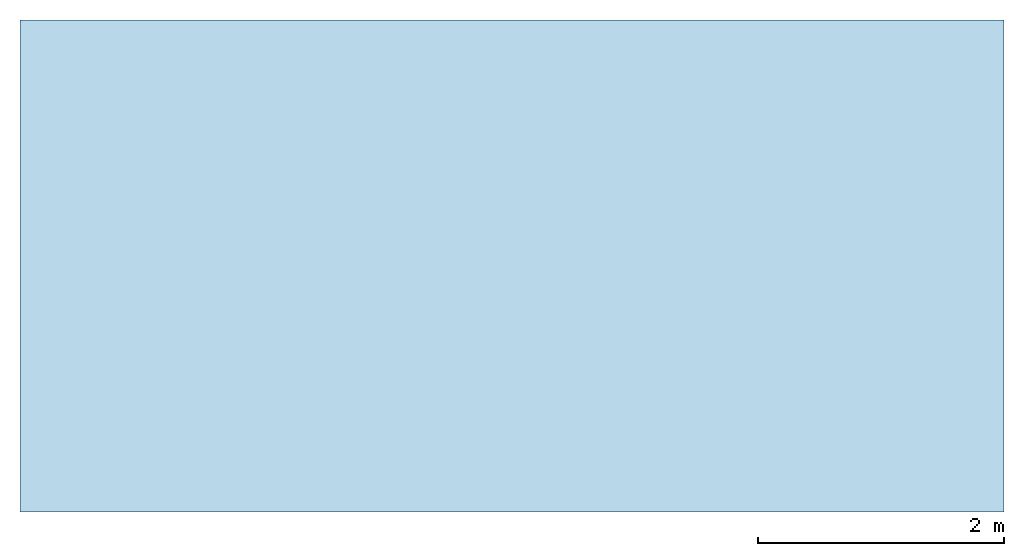
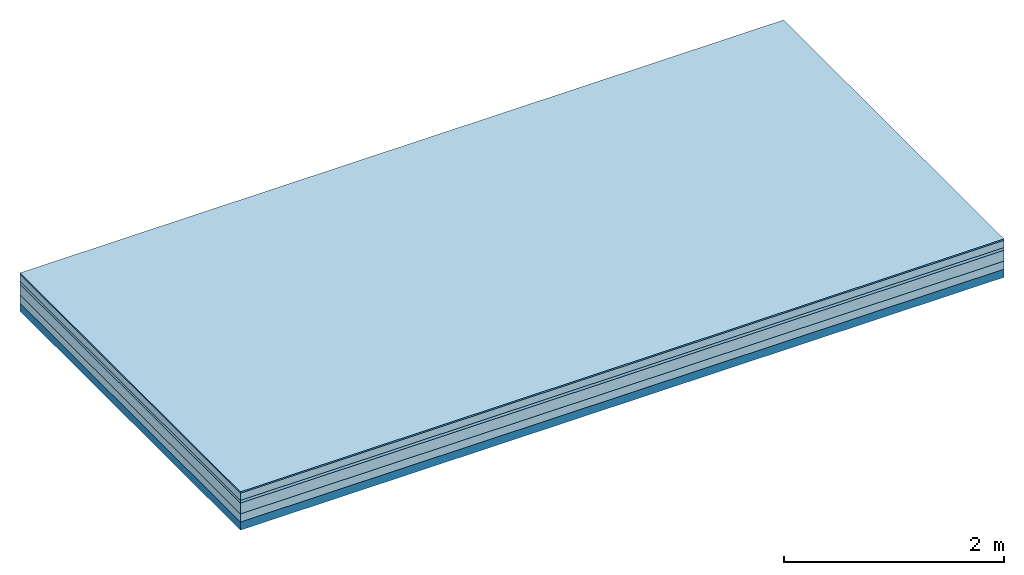
# One storey: 5 plates, 1 member, 1 element without a shape of its own.
"""IFC4 building model written with IfcOpenShell, lengths in metres."""

from ifc_helpers import new_model, si_unit, derived_unit, direction, frame, frame_2d, origin, origin_with_axes, place, context, project, spatial, rectangle, extrude, material, layer, layer_set, type_object, element, aggregate, save


model = new_model("IFC4")

# Units and contexts
plan_context = context("Plan", 3, precision=1e-05, world=origin(), true_north=direction((0.0, 1.0)))
model_context = context("Model", 3, precision=1e-05, world=origin(), true_north=direction((0.0, 1.0)))
ifc_project = project(units=[si_unit("LENGTHUNIT", "METRE"), derived_unit("SOUNDPRESSUREUNIT", [(si_unit("PRESSUREUNIT", "PASCAL", prefix="MICRO"), 0)]), si_unit("ENERGYUNIT", "JOULE", prefix="MEGA"), si_unit("MASSUNIT", "GRAM", prefix="KILO"), derived_unit("THERMALTRANSMITTANCEUNIT", [(si_unit("POWERUNIT", "WATT"), 1), (si_unit("AREAUNIT", "SQUARE_METRE"), -1), (si_unit("THERMODYNAMICTEMPERATUREUNIT", "KELVIN"), -1)]), derived_unit("AREADENSITYUNIT", [(si_unit("MASSUNIT", "GRAM", prefix="KILO"), 1), (si_unit("AREAUNIT", "SQUARE_METRE"), -1)]), derived_unit("USERDEFINED", [(si_unit("ENERGYUNIT", "JOULE", prefix="MEGA"), 1), (si_unit("AREAUNIT", "SQUARE_METRE"), -1)])], contexts=[plan_context, model_context])

# Site, building, storey
site = spatial("IfcSite", under=ifc_project)
building_placement = place(None, origin())
building = spatial("IfcBuilding", under=site, at=building_placement)
storey_placement = place(building_placement, origin())
storey = spatial("IfcBuildingStorey", under=building, at=storey_placement)

# Slab, member, plates
ifc_material_1 = material(Category="11.013")
ifc_layer_1 = layer(ifc_material_1, 0.015, Name="Flooring")
ifc_material_2 = material(Name="Cement screed", Category="04.006")
ifc_layer_2 = layer(ifc_material_2, 0.08, Name="On-material")
ifc_material_3 = material(Name="Wood fiber generic product", Category="10.009")
ifc_layer_3 = layer(ifc_material_3, 0.03, Name="Impact sound insulation")
ifc_material_4 = material(Name="Cement screed with EPS", Category="04.006")
ifc_layer_4 = layer(ifc_material_4, 0.12, Name="on Supporting structure")
ifc_material_5 = material(Category="01.002")
ifc_layer_5 = layer(ifc_material_5, 0.09, Name="Sub-floor")
ifc_material_6 = material(Name="Rigid, of the art")
ifc_layer_6 = layer(ifc_material_6, 0.0, Name="Bond")
ifc_layer_7 = layer(None, 0.09, Name="Supporting structure")
ifc_layer_set = layer_set([ifc_layer_1, ifc_layer_2, ifc_layer_3, ifc_layer_4, ifc_layer_5, ifc_layer_6, ifc_layer_7])
slab_type = type_object("IfcSlabType", Name="A2216", PredefinedType="NOTDEFINED", material=ifc_layer_set)
slab_placement = place(None, frame((0.0, 0.0, 0.0), z_axis=(0.0, 0.0, -1.0), x_axis=(1.0, 0.0, 0.0)))
slab = element("IfcSlab", 1, at=slab_placement, inside=storey, type_object=slab_type, material=ifc_layer_set, Name="Slab #1")
ifc_material_7 = material(Name="Solid timber panel")
member_placement = place(slab_placement, origin())
member = element("IfcMember", 2, at=member_placement, material=ifc_material_7, Name="Supporting structure", context=plan_context, shape_type="SweptSolid", body=[
    extrude(rectangle(XDim=1.0, YDim=0.09, at=frame_2d((0.5, 0.045), x_axis=(1.0, 0.0))), frame((0.0, 4.0, 0.335), z_axis=(0.0, -1.0, 0.0), x_axis=(1.0, 0.0, 0.0)), (0.0, 0.0, 1.0), 4.0),
    extrude(rectangle(XDim=1.0, YDim=0.09, at=frame_2d((0.5, 0.045), x_axis=(1.0, 0.0))), frame((1.0, 4.0, 0.335), z_axis=(0.0, -1.0, 0.0), x_axis=(1.0, 0.0, 0.0)), (0.0, 0.0, 1.0), 4.0),
    extrude(rectangle(XDim=1.0, YDim=0.09, at=frame_2d((0.5, 0.045), x_axis=(1.0, 0.0))), frame((2.0, 4.0, 0.335), z_axis=(0.0, -1.0, 0.0), x_axis=(1.0, 0.0, 0.0)), (0.0, 0.0, 1.0), 4.0),
    extrude(rectangle(XDim=1.0, YDim=0.09, at=frame_2d((0.5, 0.045), x_axis=(1.0, 0.0))), frame((3.0, 4.0, 0.335), z_axis=(0.0, -1.0, 0.0), x_axis=(1.0, 0.0, 0.0)), (0.0, 0.0, 1.0), 4.0),
    extrude(rectangle(XDim=1.0, YDim=0.09, at=frame_2d((0.5, 0.045), x_axis=(1.0, 0.0))), frame((4.0, 4.0, 0.335), z_axis=(0.0, -1.0, 0.0), x_axis=(1.0, 0.0, 0.0)), (0.0, 0.0, 1.0), 4.0),
    extrude(rectangle(XDim=1.0, YDim=0.09, at=frame_2d((0.5, 0.045), x_axis=(1.0, 0.0))), frame((5.0, 4.0, 0.335), z_axis=(0.0, -1.0, 0.0), x_axis=(1.0, 0.0, 0.0)), (0.0, 0.0, 1.0), 4.0),
    extrude(rectangle(XDim=1.0, YDim=0.09, at=frame_2d((0.5, 0.045), x_axis=(1.0, 0.0))), frame((6.0, 4.0, 0.335), z_axis=(0.0, -1.0, 0.0), x_axis=(1.0, 0.0, 0.0)), (0.0, 0.0, 1.0), 4.0),
    extrude(rectangle(XDim=1.0, YDim=0.09, at=frame_2d((0.5, 0.045), x_axis=(1.0, 0.0))), frame((7.0, 4.0, 0.335), z_axis=(0.0, -1.0, 0.0), x_axis=(1.0, 0.0, 0.0)), (0.0, 0.0, 1.0), 4.0),
])
plate_1_placement = place(slab_placement, origin())
plate_1 = element("IfcPlate", 3, at=plate_1_placement, material=ifc_material_1, Name="Flooring", context=plan_context, shape_type="SweptSolid", body=[
    extrude(rectangle(XDim=8.0, YDim=4.0, at=frame_2d((4.0, 2.0), x_axis=(1.0, 0.0))), origin_with_axes(), (0.0, 0.0, 1.0), 0.015),
])
plate_2_placement = place(slab_placement, origin())
plate_2 = element("IfcPlate", 4, at=plate_2_placement, material=ifc_material_2, Name="On-material", context=plan_context, shape_type="SweptSolid", body=[
    extrude(rectangle(XDim=8.0, YDim=4.0, at=frame_2d((4.0, 2.0), x_axis=(1.0, 0.0))), frame((0.0, 0.0, 0.015), z_axis=(0.0, 0.0, 1.0), x_axis=(1.0, 0.0, 0.0)), (0.0, 0.0, 1.0), 0.08),
])
plate_3_placement = place(slab_placement, origin())
plate_3 = element("IfcPlate", 5, at=plate_3_placement, material=ifc_material_3, Name="Impact sound insulation", context=plan_context, shape_type="SweptSolid", body=[
    extrude(rectangle(XDim=8.0, YDim=4.0, at=frame_2d((4.0, 2.0), x_axis=(1.0, 0.0))), frame((0.0, 0.0, 0.095), z_axis=(0.0, 0.0, 1.0), x_axis=(1.0, 0.0, 0.0)), (0.0, 0.0, 1.0), 0.03),
])
plate_4_placement = place(slab_placement, origin())
plate_4 = element("IfcPlate", 6, at=plate_4_placement, material=ifc_material_4, Name="on Supporting structure", context=plan_context, shape_type="SweptSolid", body=[
    extrude(rectangle(XDim=8.0, YDim=4.0, at=frame_2d((4.0, 2.0), x_axis=(1.0, 0.0))), frame((0.0, 0.0, 0.125), z_axis=(0.0, 0.0, 1.0), x_axis=(1.0, 0.0, 0.0)), (0.0, 0.0, 1.0), 0.12),
])
plate_5_placement = place(slab_placement, origin())
plate_5 = element("IfcPlate", 7, at=plate_5_placement, material=ifc_material_5, Name="Sub-floor", context=plan_context, shape_type="SweptSolid", body=[
    extrude(rectangle(XDim=8.0, YDim=4.0, at=frame_2d((4.0, 2.0), x_axis=(1.0, 0.0))), frame((0.0, 0.0, 0.245), z_axis=(0.0, 0.0, 1.0), x_axis=(1.0, 0.0, 0.0)), (0.0, 0.0, 1.0), 0.09),
])
aggregate(slab, [plate_1, plate_2, plate_3, plate_4, plate_5, member])

save(model, "model.ifc")
